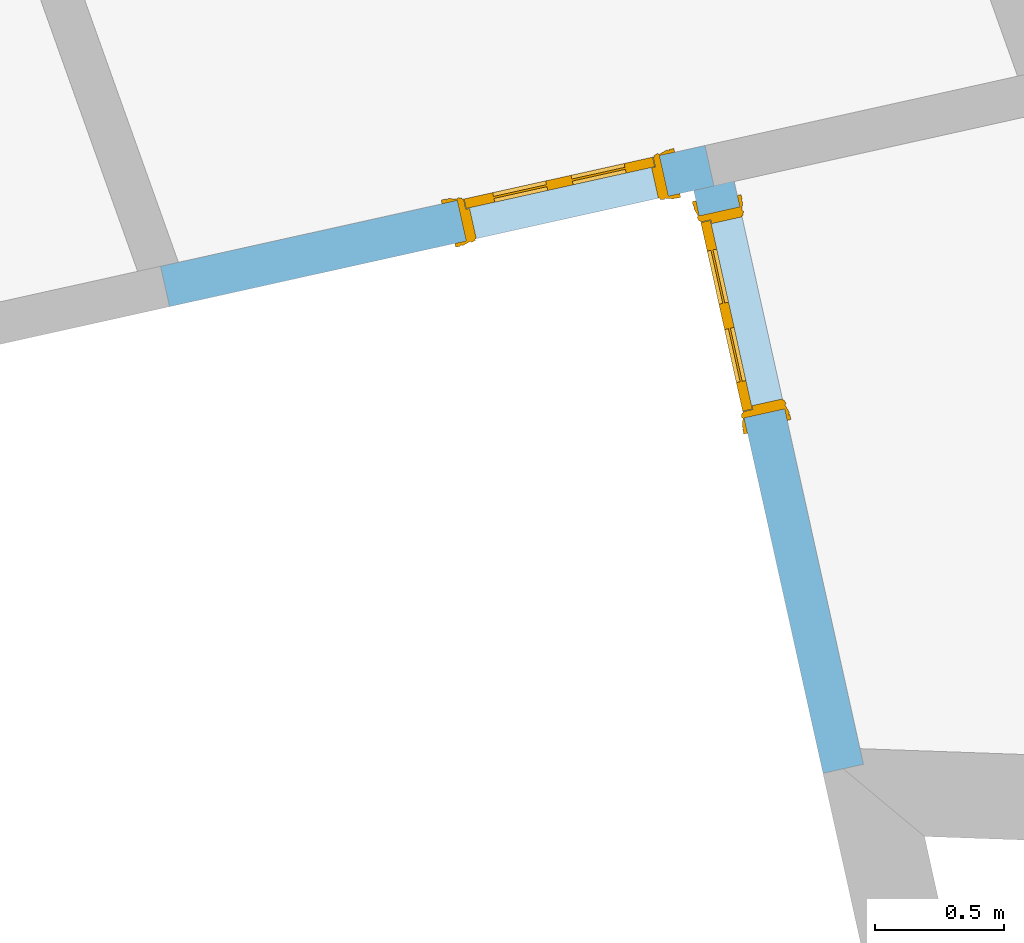
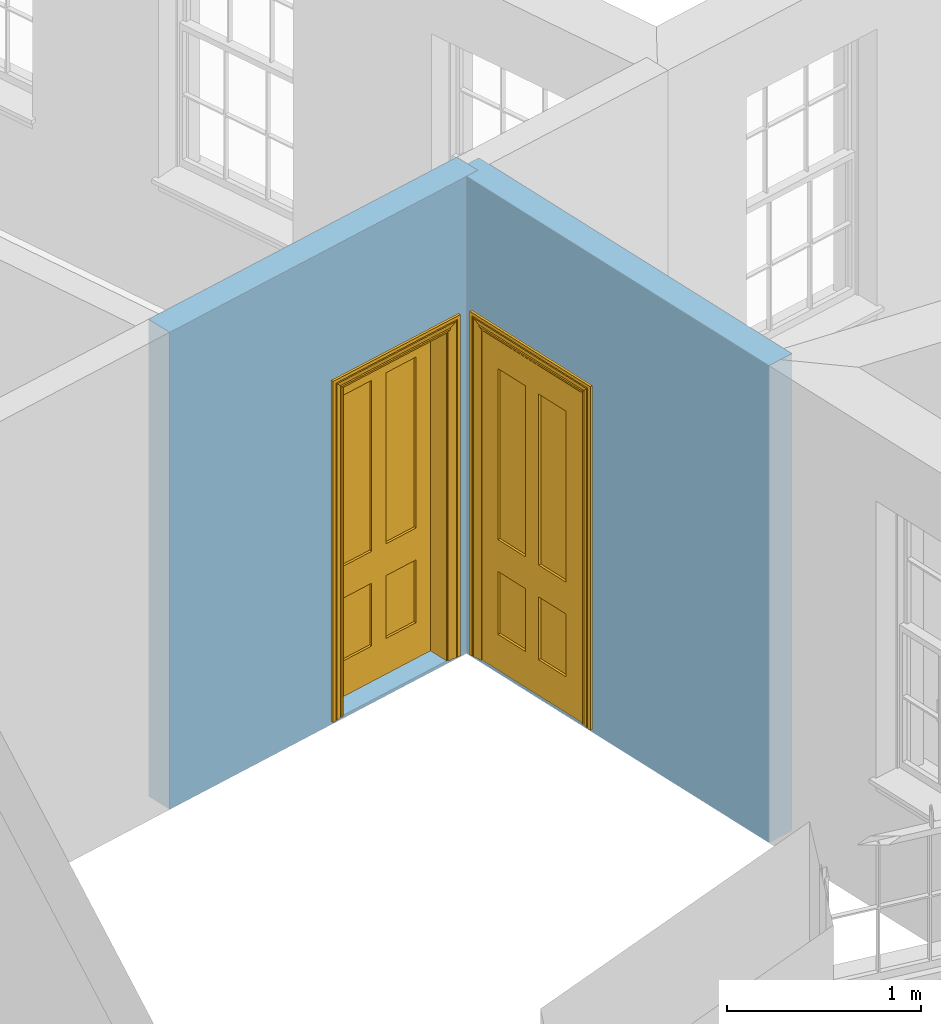
# One storey, part 7 of 10: 2 doors, 2 openings, plus 2 elements that do not belong to this part.
"""IFC2X3 building model written with IfcOpenShell, lengths in metres."""

from ifc_helpers import new_model, si_unit, frame, origin, place, context, subcontext, project, spatial, polyline, outline, extrude, faceted_brep, material, layer, layer_set, layer_usage, element, fill, save


model = new_model("IFC2X3")

# Units and contexts
model_context = context("Model", 3, world=origin())
body_context = subcontext(model_context, "Body", "Model", "MODEL_VIEW")
ifc_project = project(units=[si_unit("PLANEANGLEUNIT", "RADIAN"), si_unit("MASSUNIT", "GRAM", prefix="KILO"), si_unit("FORCEUNIT", "NEWTON", prefix="KILO"), si_unit("LENGTHUNIT", "METRE")], contexts=[model_context])

# Site, building, storey
site_placement = place(None, origin())
site = spatial("IfcSite", under=ifc_project, at=site_placement, CompositionType="ELEMENT")
building_placement = place(None, origin())
building = spatial("IfcBuilding", under=site, at=building_placement, Name="Building plot-16", CompositionType="ELEMENT")
storey_placement = place(None, frame((0.0, 0.0, 6.0)))
storey = spatial("IfcBuildingStorey", under=building, at=storey_placement, Name="Floor 1", CompositionType="ELEMENT", Elevation=6.0)

# Wall, opening, door
ifc_material = material(Name="Masonry")
ifc_layer = layer(ifc_material, 0.16, ventilated=False)
ifc_layer_set = layer_set([ifc_layer], Name="My Wall")
ifc_layer_usage = layer_usage(ifc_layer_set, "AXIS2", "NEGATIVE", 0.08)
wall_1_placement = place(storey_placement, origin())
wall_1 = element("IfcWallStandardCase", 1, at=wall_1_placement, inside=storey, material=ifc_layer_usage, Name="interior", context=body_context, shape_type="SweptSolid", body=[
    extrude(outline(polyline([(96.6294918891393, 33.110627952855), (96.7856970241385, 33.1452683310264), (96.2692996331396, 35.4738781335823), (96.1130944981404, 35.4392377554109), (96.6294918891393, 33.110627952855)])), origin(), (0.0, 0.0, 1.0), 3.0),
])
opening_1_placement = place(storey_placement, frame((0.0, 0.0, 0.0199999999999996)))
opening_1 = element("IfcOpeningElement", 2, at=opening_1_placement, cuts=wall_1, Name="Opening", ObjectType="Opening", context=body_context, shape_type="SweptSolid", body=[
    extrude(outline(polyline([(96.4814719494397, 34.5171216817118), (96.3082700585825, 35.2981473567081), (96.1520649235832, 35.2635069785367), (96.3252668144404, 34.4824813035404), (96.4814719494397, 34.5171216817118)])), origin(), (0.0, 0.0, 1.0), 2.1),
])
door_1_placement = place(storey_placement, frame((96.4033693819401, 34.4998014926261, 0.0199999999999996), z_axis=(0.0, 0.0, 1.0), x_axis=(-0.173201890857186, 0.781025674996343, 0.0)))
door_1 = element("IfcDoor", 3, at=door_1_placement, inside=storey, Name="bedroom inside door", OverallHeight=2.1, OverallWidth=0.8, context=body_context, shape_type="Brep", held_by="IfcProductRepresentation", body=[
    faceted_brep([(0.773, 0.08, 1.895), (0.66, 0.08, 1.895), (0.66, 0.08, 2.073), (0.773, 0.08, 2.073), (0.773, 0.08, 0.82), (0.66, 0.08, 0.82), (0.45, 0.08, 1.895), (0.45, 0.08, 2.073), (0.773, 0.08, 0.62), (0.66, 0.08, 0.62), (0.66, 0.065, 0.82), (0.66, 0.065, 1.895), (0.45, 0.065, 1.895), (0.35, 0.08, 1.895), (0.35, 0.08, 2.073), (0.773, 0.08, 0.225), (0.66, 0.08, 0.225), (0.45, 0.08, 0.62), (0.45, 0.08, 0.82), (0.45, 0.065, 0.82), (0.35, 0.08, 0.82), (0.14, 0.08, 2.073), (0.14, 0.08, 1.895), (0.773, 0.08, 0.0), (0.66, 0.08, 0.0), (0.66, 0.065, 0.225), (0.66, 0.065, 0.62), (0.45, 0.065, 0.62), (0.35, 0.08, 0.62), (0.35, 0.065, 0.82), (0.35, 0.065, 1.895), (0.14, 0.065, 1.895), (0.027, 0.08, 2.073), (0.027, 0.08, 1.895), (0.773, 0.042, 0.0), (0.66, 0.042, 0.0), (0.45, 0.08, 0.0), (0.45, 0.08, 0.225), (0.45, 0.065, 0.225), (0.35, 0.08, 0.225), (0.14, 0.08, 0.82), (0.14, 0.08, 0.62), (0.14, 0.065, 0.82), (0.027, 0.08, 0.82), (0.773, 0.042, 0.225), (0.66, 0.042, 0.225), (0.45, 0.042, 0.0), (0.35, 0.08, 0.0), (0.35, 0.065, 0.225), (0.35, 0.065, 0.62), (0.14, 0.065, 0.62), (0.027, 0.08, 0.62), (0.773, 0.042, 0.62), (0.66, 0.042, 0.62), (0.45, 0.042, 0.225), (0.35, 0.042, 0.0), (0.14, 0.08, 0.225), (0.14, 0.08, 0.0), (0.14, 0.065, 0.225), (0.027, 0.08, 0.225), (0.773, 0.042, 0.82), (0.66, 0.042, 0.82), (0.66, 0.057, 0.62), (0.66, 0.057, 0.225), (0.45, 0.057, 0.225), (0.35, 0.042, 0.225), (0.14, 0.042, 0.0), (0.027, 0.08, 0.0), (0.773, 0.042, 1.895), (0.66, 0.042, 1.895), (0.45, 0.042, 0.62), (0.45, 0.042, 0.82), (0.45, 0.057, 0.62), (0.35, 0.042, 0.62), (0.14, 0.042, 0.225), (0.027, 0.042, 0.0), (0.773, 0.042, 2.073), (0.66, 0.042, 2.073), (0.66, 0.057, 1.895), (0.66, 0.057, 0.82), (0.45, 0.057, 0.82), (0.35, 0.042, 0.82), (0.35, 0.057, 0.62), (0.35, 0.057, 0.225), (0.14, 0.057, 0.225), (0.027, 0.042, 0.225), (0.45, 0.042, 1.895), (0.45, 0.042, 2.073), (0.45, 0.057, 1.895), (0.35, 0.042, 1.895), (0.14, 0.042, 0.82), (0.14, 0.042, 0.62), (0.14, 0.057, 0.62), (0.027, 0.042, 0.62), (0.35, 0.042, 2.073), (0.35, 0.057, 1.895), (0.35, 0.057, 0.82), (0.14, 0.057, 0.82), (0.027, 0.042, 0.82), (0.14, 0.042, 2.073), (0.14, 0.042, 1.895), (0.14, 0.057, 1.895), (0.027, 0.042, 1.895), (0.027, 0.042, 2.073), (0.02, 0.085, 0.0), (0.005, 0.09, 0.0), (0.005, 0.09, 2.095), (0.02, 0.085, 2.08), (0.02, 0.08, 0.0), (0.0, 0.085, 0.0), (0.0, 0.085, 2.1), (0.795, 0.09, 2.095), (0.78, 0.085, 2.08), (0.02, 0.08, 2.08), (0.0, 0.08, 0.0), (-0.032, 0.095, 0.0), (-0.032, 0.095, 2.132), (0.8, 0.085, 2.1), (0.795, 0.09, 0.0), (0.78, 0.085, 0.0), (0.78, 0.08, 2.08), (0.04, 0.04, 0.0), (0.025, 0.04, 0.0), (0.025, 0.04, 2.075), (0.04, 0.04, 2.06), (-0.04, 0.09, 0.0), (-0.04, 0.09, 2.14), (0.832, 0.095, 2.132), (0.8, 0.085, 0.0), (0.78, 0.08, 0.0), (0.8, 0.08, 0.0), (0.86, 0.08, 0.0), (0.86, 0.08, 2.16), (0.8, 0.08, 2.1), (-0.06, 0.08, 2.16), (0.0, 0.08, 2.1), (-0.06, 0.08, 0.0), (-0.04, 0.095, 0.0), (-0.04, 0.095, 2.14), (0.84, 0.09, 2.14), (0.832, 0.095, 0.0), (0.84, 0.09, 0.0), (0.86, 0.095, 0.0), (0.86, 0.095, 2.16), (-0.06, 0.095, 2.16), (-0.06, 0.095, 0.0), (0.84, 0.095, 0.0), (0.84, 0.095, 2.14), (-0.025, -0.095, 0.0), (-0.025, -0.09, 0.0), (-0.025, -0.09, 2.125), (-0.025, -0.095, 2.125), (-0.017, -0.095, 0.0), (-0.017, -0.095, 2.117), (0.825, -0.09, 2.125), (0.825, -0.095, 2.125), (0.825, -0.095, 0.0), (0.845, -0.095, 0.0), (-0.045, -0.095, 2.145), (-0.045, -0.095, 0.0), (0.845, -0.095, 2.145), (0.015, -0.085, 0.0), (0.015, -0.085, 2.085), (0.817, -0.095, 2.117), (0.825, -0.09, 0.0), (0.845, -0.08, 0.0), (0.845, -0.08, 2.145), (-0.045, -0.08, 2.145), (-0.045, -0.08, 0.0), (0.02, -0.09, 0.0), (0.02, -0.09, 2.08), (0.785, -0.085, 2.085), (0.817, -0.095, 0.0), (0.8, -0.08, 0.0), (0.8, -0.08, 2.1), (0.0, -0.08, 2.1), (0.0, -0.08, 0.0), (0.035, -0.085, 0.0), (0.035, -0.085, 2.065), (0.78, -0.09, 2.08), (0.785, -0.085, 0.0), (0.775, 0.04, 2.075), (0.76, 0.04, 2.06), (0.035, -0.08, 2.065), (0.035, -0.08, 0.0), (0.765, -0.085, 2.065), (0.78, -0.09, 0.0), (0.765, -0.08, 0.0), (0.765, -0.08, 2.065), (0.765, -0.085, 0.0), (0.04, -0.08, 2.06), (0.04, -0.08, 0.0), (0.76, -0.08, 2.06), (0.76, -0.08, 0.0), (0.76, 0.04, 0.0), (0.775, 0.04, 0.0), (0.025, 0.08, 0.0), (0.025, 0.08, 2.075), (0.775, 0.08, 0.0), (0.775, 0.08, 2.075)], [[[0, 1, 2, 3]], [[1, 0, 4, 5]], [[1, 6, 7, 2]], [[8, 9, 5, 4]], [[1, 5, 10, 11]], [[6, 1, 11, 12]], [[6, 13, 14, 7]], [[15, 16, 9, 8]], [[9, 17, 18, 5]], [[5, 18, 19, 10]], [[10, 19, 12, 11]], [[18, 6, 12, 19]], [[18, 20, 13, 6]], [[21, 14, 13, 22]], [[23, 24, 16, 15]], [[9, 16, 25, 26]], [[17, 9, 26, 27]], [[17, 28, 20, 18]], [[13, 20, 29, 30]], [[22, 13, 30, 31]], [[32, 21, 22, 33]], [[34, 35, 24, 23]], [[24, 36, 37, 16]], [[16, 37, 38, 25]], [[25, 38, 27, 26]], [[37, 17, 27, 38]], [[37, 39, 28, 17]], [[40, 20, 28, 41]], [[20, 40, 42, 29]], [[31, 30, 29, 42]], [[40, 22, 31, 42]], [[33, 22, 40, 43]], [[35, 34, 44, 45]], [[35, 46, 36, 24]], [[36, 47, 39, 37]], [[28, 39, 48, 49]], [[41, 28, 49, 50]], [[43, 40, 41, 51]], [[45, 44, 52, 53]], [[46, 35, 45, 54]], [[46, 55, 47, 36]], [[56, 39, 47, 57]], [[39, 56, 58, 48]], [[50, 49, 48, 58]], [[56, 41, 50, 58]], [[51, 41, 56, 59]], [[53, 52, 60, 61]], [[45, 53, 62, 63]], [[54, 45, 63, 64]], [[55, 46, 54, 65]], [[55, 66, 57, 47]], [[59, 56, 57, 67]], [[61, 60, 68, 69]], [[70, 53, 61, 71]], [[53, 70, 72, 62]], [[72, 64, 63, 62]], [[70, 54, 64, 72]], [[65, 54, 70, 73]], [[65, 74, 66, 55]], [[67, 57, 66, 75]], [[69, 68, 76, 77]], [[61, 69, 78, 79]], [[71, 61, 79, 80]], [[73, 70, 71, 81]], [[65, 73, 82, 83]], [[74, 65, 83, 84]], [[74, 85, 75, 66]], [[86, 69, 77, 87]], [[69, 86, 88, 78]], [[88, 80, 79, 78]], [[86, 71, 80, 88]], [[81, 71, 86, 89]], [[73, 81, 90, 91]], [[73, 91, 92, 82]], [[83, 82, 92, 84]], [[91, 74, 84, 92]], [[91, 93, 85, 74]], [[89, 86, 87, 94]], [[81, 89, 95, 96]], [[90, 81, 96, 97]], [[90, 98, 93, 91]], [[94, 99, 100, 89]], [[89, 100, 101, 95]], [[101, 97, 96, 95]], [[100, 90, 97, 101]], [[100, 102, 98, 90]], [[99, 103, 102, 100]], [[32, 103, 99, 21]], [[102, 103, 32, 33]], [[98, 102, 33, 43]], [[21, 99, 94, 14]], [[94, 87, 7, 14]], [[7, 87, 77, 2]], [[76, 3, 2, 77]], [[43, 51, 93, 98]], [[51, 59, 85, 93]], [[67, 75, 85, 59]], [[34, 23, 15, 44]], [[44, 15, 8, 52]], [[52, 8, 4, 60]], [[0, 68, 60, 4]], [[0, 3, 76, 68]], [[104, 105, 106, 107]], [[104, 108, 109, 105]], [[105, 109, 110, 106]], [[107, 106, 111, 112]], [[107, 113, 108, 104]], [[114, 109, 108]], [[109, 115, 116, 110]], [[106, 110, 117, 111]], [[112, 111, 118, 119]], [[113, 107, 112, 120]], [[121, 122, 123, 124]], [[115, 109, 114, 125]], [[115, 125, 126, 116]], [[110, 116, 127, 117]], [[111, 117, 128, 118]], [[118, 128, 129, 119]], [[120, 112, 119, 129]], [[130, 129, 128]], [[130, 131, 132, 133]], [[133, 132, 134, 135]], [[135, 134, 136, 114]], [[136, 125, 114]], [[125, 137, 138, 126]], [[116, 126, 139, 127]], [[117, 127, 140, 128]], [[141, 130, 128, 140]], [[131, 130, 141]], [[131, 142, 143, 132]], [[132, 143, 144, 134]], [[134, 144, 145, 136]], [[137, 125, 136, 145]], [[143, 142, 146]], [[143, 146, 147]], [[137, 145, 144]], [[143, 147, 138]], [[138, 137, 144]], [[143, 138, 144]], [[126, 138, 147, 139]], [[127, 139, 141, 140]], [[142, 131, 141, 146]], [[139, 147, 146, 141]], [[148, 149, 150, 151]], [[149, 152, 153, 150]], [[151, 150, 154, 155]], [[155, 156, 157]], [[158, 159, 148]], [[158, 148, 151]], [[155, 157, 160]], [[158, 151, 155]], [[155, 160, 158]], [[152, 161, 162, 153]], [[150, 153, 163, 154]], [[155, 154, 164, 156]], [[156, 164, 165, 157]], [[157, 165, 166, 160]], [[160, 166, 167, 158]], [[158, 167, 168, 159]], [[161, 169, 170, 162]], [[153, 162, 171, 163]], [[154, 163, 172, 164]], [[165, 164, 173]], [[165, 173, 174, 166]], [[166, 174, 175, 167]], [[167, 175, 176, 168]], [[169, 177, 178, 170]], [[162, 170, 179, 171]], [[163, 171, 180, 172]], [[172, 180, 173, 164]], [[124, 123, 181, 182]], [[183, 178, 177, 184]], [[170, 178, 185, 179]], [[171, 179, 186, 180]], [[187, 173, 180]], [[185, 188, 187, 189]], [[188, 185, 178, 183]], [[179, 185, 189, 186]], [[189, 187, 180, 186]], [[190, 183, 184, 191]], [[192, 188, 183, 190]], [[191, 184, 122, 121]], [[124, 190, 191, 121]], [[193, 187, 188, 192]], [[182, 192, 190, 124]], [[184, 176, 122]], [[194, 195, 187, 193]], [[192, 182, 194, 193]], [[161, 176, 184]], [[114, 108, 122, 176]], [[173, 187, 195]], [[152, 149, 176, 161]], [[169, 161, 184, 177]], [[196, 122, 108]], [[176, 175, 135, 114]], [[173, 195, 129, 130]], [[176, 149, 168]], [[123, 122, 196, 197]], [[196, 108, 113, 197]], [[175, 174, 133, 135]], [[198, 129, 195]], [[133, 174, 173, 130]], [[159, 168, 149, 148]], [[181, 123, 197, 199]], [[197, 113, 120, 199]], [[199, 120, 129, 198]], [[195, 181, 199, 198]], [[195, 194, 182, 181]]]),
])
fill(opening_1, door_1)

wall_2_placement = place(storey_placement, origin())
wall_2 = element("IfcWallStandardCase", 4, at=wall_2_placement, inside=storey, material=ifc_layer_usage, Name="interior", context=body_context, shape_type="SweptSolid", body=[
    extrude(outline(polyline([(94.0715489961098, 35.0684438743723), (94.1061893742812, 34.9122387393731), (96.2085172547257, 35.378455376997), (96.1738768765543, 35.5346605119962), (94.0715489961098, 35.0684438743723)])), origin(), (0.0, 0.0, 1.0), 3.0),
])
opening_2_placement = place(storey_placement, frame((0.0, 0.0, 0.0199999999999996)))
opening_2 = element("IfcOpeningElement", 5, at=opening_2_placement, cuts=wall_2, Name="Opening", ObjectType="Opening", context=body_context, shape_type="SweptSolid", body=[
    extrude(outline(polyline([(95.2517608028552, 35.1662830606969), (96.0327864778515, 35.3394849515541), (95.9981460996801, 35.4956900865534), (95.2171204246837, 35.3224881956962), (95.2517608028552, 35.1662830606969)])), origin(), (0.0, 0.0, 1.0), 2.1),
])
door_2_placement = place(storey_placement, frame((95.2344406137695, 35.2443856281966, 0.0199999999999996), z_axis=(0.0, 0.0, 1.0), x_axis=(0.781025674996357, 0.173201890857172, 0.0)))
door_2 = element("IfcDoor", 6, at=door_2_placement, inside=storey, Name="bedroom inside door", OverallHeight=2.1, OverallWidth=0.8, context=body_context, shape_type="Brep", held_by="IfcProductRepresentation", body=[
    faceted_brep([(0.773, 0.08, 1.895), (0.66, 0.08, 1.895), (0.66, 0.08, 2.073), (0.773, 0.08, 2.073), (0.773, 0.08, 0.82), (0.66, 0.08, 0.82), (0.45, 0.08, 1.895), (0.45, 0.08, 2.073), (0.773, 0.08, 0.62), (0.66, 0.08, 0.62), (0.66, 0.065, 0.82), (0.66, 0.065, 1.895), (0.45, 0.065, 1.895), (0.35, 0.08, 1.895), (0.35, 0.08, 2.073), (0.773, 0.08, 0.225), (0.66, 0.08, 0.225), (0.45, 0.08, 0.62), (0.45, 0.08, 0.82), (0.45, 0.065, 0.82), (0.35, 0.08, 0.82), (0.14, 0.08, 2.073), (0.14, 0.08, 1.895), (0.773, 0.08, 0.0), (0.66, 0.08, 0.0), (0.66, 0.065, 0.225), (0.66, 0.065, 0.62), (0.45, 0.065, 0.62), (0.35, 0.08, 0.62), (0.35, 0.065, 0.82), (0.35, 0.065, 1.895), (0.14, 0.065, 1.895), (0.027, 0.08, 2.073), (0.027, 0.08, 1.895), (0.773, 0.042, 0.0), (0.66, 0.042, 0.0), (0.45, 0.08, 0.0), (0.45, 0.08, 0.225), (0.45, 0.065, 0.225), (0.35, 0.08, 0.225), (0.14, 0.08, 0.82), (0.14, 0.08, 0.62), (0.14, 0.065, 0.82), (0.027, 0.08, 0.82), (0.773, 0.042, 0.225), (0.66, 0.042, 0.225), (0.45, 0.042, 0.0), (0.35, 0.08, 0.0), (0.35, 0.065, 0.225), (0.35, 0.065, 0.62), (0.14, 0.065, 0.62), (0.027, 0.08, 0.62), (0.773, 0.042, 0.62), (0.66, 0.042, 0.62), (0.45, 0.042, 0.225), (0.35, 0.042, 0.0), (0.14, 0.08, 0.225), (0.14, 0.08, 0.0), (0.14, 0.065, 0.225), (0.027, 0.08, 0.225), (0.773, 0.042, 0.82), (0.66, 0.042, 0.82), (0.66, 0.057, 0.62), (0.66, 0.057, 0.225), (0.45, 0.057, 0.225), (0.35, 0.042, 0.225), (0.14, 0.042, 0.0), (0.027, 0.08, 0.0), (0.773, 0.042, 1.895), (0.66, 0.042, 1.895), (0.45, 0.042, 0.62), (0.45, 0.042, 0.82), (0.45, 0.057, 0.62), (0.35, 0.042, 0.62), (0.14, 0.042, 0.225), (0.027, 0.042, 0.0), (0.773, 0.042, 2.073), (0.66, 0.042, 2.073), (0.66, 0.057, 1.895), (0.66, 0.057, 0.82), (0.45, 0.057, 0.82), (0.35, 0.042, 0.82), (0.35, 0.057, 0.62), (0.35, 0.057, 0.225), (0.14, 0.057, 0.225), (0.027, 0.042, 0.225), (0.45, 0.042, 1.895), (0.45, 0.042, 2.073), (0.45, 0.057, 1.895), (0.35, 0.042, 1.895), (0.14, 0.042, 0.82), (0.14, 0.042, 0.62), (0.14, 0.057, 0.62), (0.027, 0.042, 0.62), (0.35, 0.042, 2.073), (0.35, 0.057, 1.895), (0.35, 0.057, 0.82), (0.14, 0.057, 0.82), (0.027, 0.042, 0.82), (0.14, 0.042, 2.073), (0.14, 0.042, 1.895), (0.14, 0.057, 1.895), (0.027, 0.042, 1.895), (0.027, 0.042, 2.073), (0.02, 0.085, 0.0), (0.005, 0.09, 0.0), (0.005, 0.09, 2.095), (0.02, 0.085, 2.08), (0.02, 0.08, 0.0), (0.0, 0.085, 0.0), (0.0, 0.085, 2.1), (0.795, 0.09, 2.095), (0.78, 0.085, 2.08), (0.02, 0.08, 2.08), (0.0, 0.08, 0.0), (-0.032, 0.095, 0.0), (-0.032, 0.095, 2.132), (0.8, 0.085, 2.1), (0.795, 0.09, 0.0), (0.78, 0.085, 0.0), (0.78, 0.08, 2.08), (0.04, 0.04, 0.0), (0.025, 0.04, 0.0), (0.025, 0.04, 2.075), (0.04, 0.04, 2.06), (-0.04, 0.09, 0.0), (-0.04, 0.09, 2.14), (0.832, 0.095, 2.132), (0.8, 0.085, 0.0), (0.78, 0.08, 0.0), (0.8, 0.08, 0.0), (0.86, 0.08, 0.0), (0.86, 0.08, 2.16), (0.8, 0.08, 2.1), (-0.06, 0.08, 2.16), (0.0, 0.08, 2.1), (-0.06, 0.08, 0.0), (-0.04, 0.095, 0.0), (-0.04, 0.095, 2.14), (0.84, 0.09, 2.14), (0.832, 0.095, 0.0), (0.84, 0.09, 0.0), (0.86, 0.095, 0.0), (0.86, 0.095, 2.16), (-0.06, 0.095, 2.16), (-0.06, 0.095, 0.0), (0.84, 0.095, 0.0), (0.84, 0.095, 2.14), (-0.025, -0.095, 0.0), (-0.025, -0.09, 0.0), (-0.025, -0.09, 2.125), (-0.025, -0.095, 2.125), (-0.017, -0.095, 0.0), (-0.017, -0.095, 2.117), (0.825, -0.09, 2.125), (0.825, -0.095, 2.125), (0.825, -0.095, 0.0), (0.845, -0.095, 0.0), (-0.045, -0.095, 2.145), (-0.045, -0.095, 0.0), (0.845, -0.095, 2.145), (0.015, -0.085, 0.0), (0.015, -0.085, 2.085), (0.817, -0.095, 2.117), (0.825, -0.09, 0.0), (0.845, -0.08, 0.0), (0.845, -0.08, 2.145), (-0.045, -0.08, 2.145), (-0.045, -0.08, 0.0), (0.02, -0.09, 0.0), (0.02, -0.09, 2.08), (0.785, -0.085, 2.085), (0.817, -0.095, 0.0), (0.8, -0.08, 0.0), (0.8, -0.08, 2.1), (0.0, -0.08, 2.1), (0.0, -0.08, 0.0), (0.035, -0.085, 0.0), (0.035, -0.085, 2.065), (0.78, -0.09, 2.08), (0.785, -0.085, 0.0), (0.775, 0.04, 2.075), (0.76, 0.04, 2.06), (0.035, -0.08, 2.065), (0.035, -0.08, 0.0), (0.765, -0.085, 2.065), (0.78, -0.09, 0.0), (0.765, -0.08, 0.0), (0.765, -0.08, 2.065), (0.765, -0.085, 0.0), (0.04, -0.08, 2.06), (0.04, -0.08, 0.0), (0.76, -0.08, 2.06), (0.76, -0.08, 0.0), (0.76, 0.04, 0.0), (0.775, 0.04, 0.0), (0.025, 0.08, 0.0), (0.025, 0.08, 2.075), (0.775, 0.08, 0.0), (0.775, 0.08, 2.075)], [[[0, 1, 2, 3]], [[1, 0, 4, 5]], [[1, 6, 7, 2]], [[8, 9, 5, 4]], [[1, 5, 10, 11]], [[6, 1, 11, 12]], [[6, 13, 14, 7]], [[15, 16, 9, 8]], [[9, 17, 18, 5]], [[5, 18, 19, 10]], [[10, 19, 12, 11]], [[18, 6, 12, 19]], [[18, 20, 13, 6]], [[21, 14, 13, 22]], [[23, 24, 16, 15]], [[9, 16, 25, 26]], [[17, 9, 26, 27]], [[17, 28, 20, 18]], [[13, 20, 29, 30]], [[22, 13, 30, 31]], [[32, 21, 22, 33]], [[34, 35, 24, 23]], [[24, 36, 37, 16]], [[16, 37, 38, 25]], [[25, 38, 27, 26]], [[37, 17, 27, 38]], [[37, 39, 28, 17]], [[40, 20, 28, 41]], [[20, 40, 42, 29]], [[31, 30, 29, 42]], [[40, 22, 31, 42]], [[33, 22, 40, 43]], [[35, 34, 44, 45]], [[35, 46, 36, 24]], [[36, 47, 39, 37]], [[28, 39, 48, 49]], [[41, 28, 49, 50]], [[43, 40, 41, 51]], [[45, 44, 52, 53]], [[46, 35, 45, 54]], [[46, 55, 47, 36]], [[56, 39, 47, 57]], [[39, 56, 58, 48]], [[50, 49, 48, 58]], [[56, 41, 50, 58]], [[51, 41, 56, 59]], [[53, 52, 60, 61]], [[45, 53, 62, 63]], [[54, 45, 63, 64]], [[55, 46, 54, 65]], [[55, 66, 57, 47]], [[59, 56, 57, 67]], [[61, 60, 68, 69]], [[70, 53, 61, 71]], [[53, 70, 72, 62]], [[72, 64, 63, 62]], [[70, 54, 64, 72]], [[65, 54, 70, 73]], [[65, 74, 66, 55]], [[67, 57, 66, 75]], [[69, 68, 76, 77]], [[61, 69, 78, 79]], [[71, 61, 79, 80]], [[73, 70, 71, 81]], [[65, 73, 82, 83]], [[74, 65, 83, 84]], [[74, 85, 75, 66]], [[86, 69, 77, 87]], [[69, 86, 88, 78]], [[88, 80, 79, 78]], [[86, 71, 80, 88]], [[81, 71, 86, 89]], [[73, 81, 90, 91]], [[73, 91, 92, 82]], [[83, 82, 92, 84]], [[91, 74, 84, 92]], [[91, 93, 85, 74]], [[89, 86, 87, 94]], [[81, 89, 95, 96]], [[90, 81, 96, 97]], [[90, 98, 93, 91]], [[94, 99, 100, 89]], [[89, 100, 101, 95]], [[101, 97, 96, 95]], [[100, 90, 97, 101]], [[100, 102, 98, 90]], [[99, 103, 102, 100]], [[32, 103, 99, 21]], [[102, 103, 32, 33]], [[98, 102, 33, 43]], [[21, 99, 94, 14]], [[94, 87, 7, 14]], [[7, 87, 77, 2]], [[76, 3, 2, 77]], [[43, 51, 93, 98]], [[51, 59, 85, 93]], [[67, 75, 85, 59]], [[34, 23, 15, 44]], [[44, 15, 8, 52]], [[52, 8, 4, 60]], [[0, 68, 60, 4]], [[0, 3, 76, 68]], [[104, 105, 106, 107]], [[104, 108, 109, 105]], [[105, 109, 110, 106]], [[107, 106, 111, 112]], [[107, 113, 108, 104]], [[114, 109, 108]], [[109, 115, 116, 110]], [[106, 110, 117, 111]], [[112, 111, 118, 119]], [[113, 107, 112, 120]], [[121, 122, 123, 124]], [[115, 109, 114, 125]], [[115, 125, 126, 116]], [[110, 116, 127, 117]], [[111, 117, 128, 118]], [[118, 128, 129, 119]], [[120, 112, 119, 129]], [[130, 129, 128]], [[130, 131, 132, 133]], [[133, 132, 134, 135]], [[135, 134, 136, 114]], [[136, 125, 114]], [[125, 137, 138, 126]], [[116, 126, 139, 127]], [[117, 127, 140, 128]], [[141, 130, 128, 140]], [[131, 130, 141]], [[131, 142, 143, 132]], [[132, 143, 144, 134]], [[134, 144, 145, 136]], [[137, 125, 136, 145]], [[143, 142, 146]], [[143, 146, 147]], [[137, 145, 144]], [[143, 147, 138]], [[138, 137, 144]], [[143, 138, 144]], [[126, 138, 147, 139]], [[127, 139, 141, 140]], [[142, 131, 141, 146]], [[139, 147, 146, 141]], [[148, 149, 150, 151]], [[149, 152, 153, 150]], [[151, 150, 154, 155]], [[155, 156, 157]], [[158, 159, 148]], [[158, 148, 151]], [[155, 157, 160]], [[158, 151, 155]], [[155, 160, 158]], [[152, 161, 162, 153]], [[150, 153, 163, 154]], [[155, 154, 164, 156]], [[156, 164, 165, 157]], [[157, 165, 166, 160]], [[160, 166, 167, 158]], [[158, 167, 168, 159]], [[161, 169, 170, 162]], [[153, 162, 171, 163]], [[154, 163, 172, 164]], [[165, 164, 173]], [[165, 173, 174, 166]], [[166, 174, 175, 167]], [[167, 175, 176, 168]], [[169, 177, 178, 170]], [[162, 170, 179, 171]], [[163, 171, 180, 172]], [[172, 180, 173, 164]], [[124, 123, 181, 182]], [[183, 178, 177, 184]], [[170, 178, 185, 179]], [[171, 179, 186, 180]], [[187, 173, 180]], [[185, 188, 187, 189]], [[188, 185, 178, 183]], [[179, 185, 189, 186]], [[189, 187, 180, 186]], [[190, 183, 184, 191]], [[192, 188, 183, 190]], [[191, 184, 122, 121]], [[124, 190, 191, 121]], [[193, 187, 188, 192]], [[182, 192, 190, 124]], [[184, 176, 122]], [[194, 195, 187, 193]], [[192, 182, 194, 193]], [[161, 176, 184]], [[114, 108, 122, 176]], [[173, 187, 195]], [[152, 149, 176, 161]], [[169, 161, 184, 177]], [[196, 122, 108]], [[176, 175, 135, 114]], [[173, 195, 129, 130]], [[176, 149, 168]], [[123, 122, 196, 197]], [[196, 108, 113, 197]], [[175, 174, 133, 135]], [[198, 129, 195]], [[133, 174, 173, 130]], [[159, 168, 149, 148]], [[181, 123, 197, 199]], [[197, 113, 120, 199]], [[199, 120, 129, 198]], [[195, 181, 199, 198]], [[195, 194, 182, 181]]]),
])
fill(opening_2, door_2)

save(model, "model.ifc")
